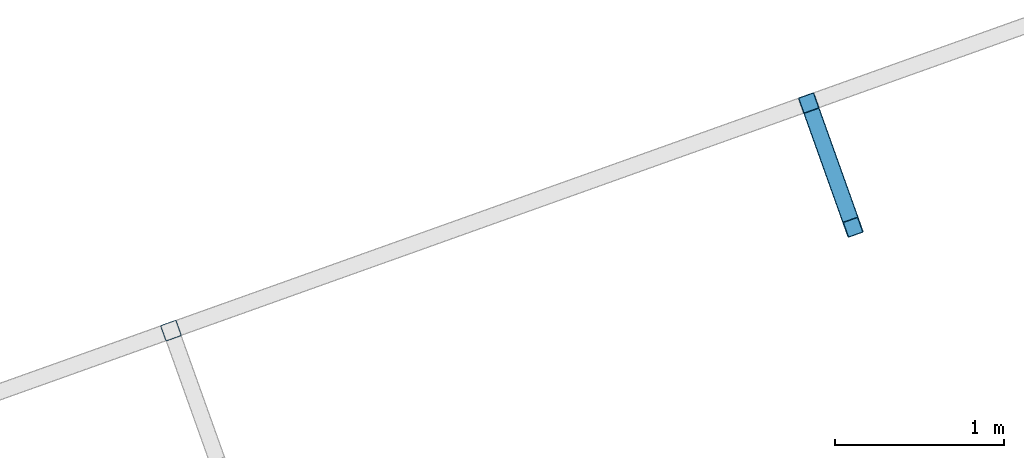
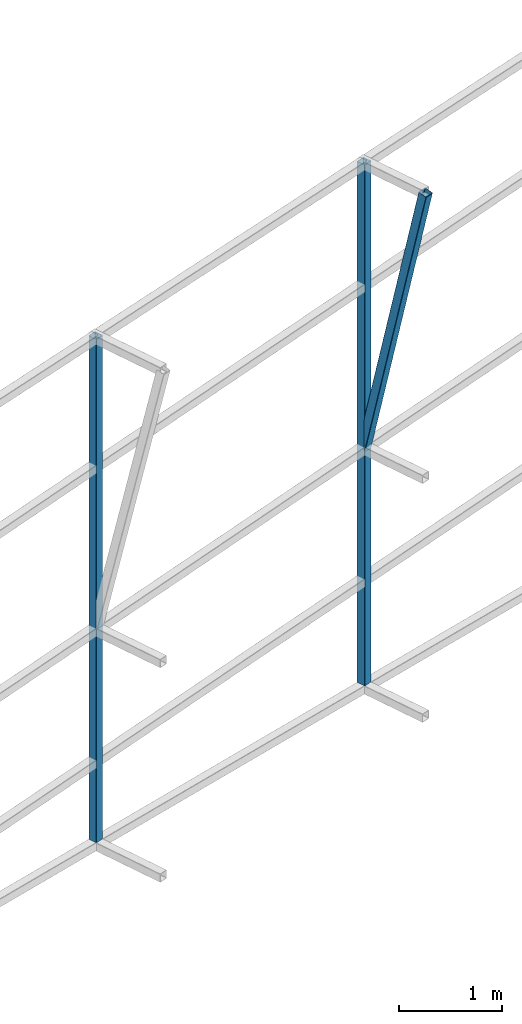
# One storey, part 132 of 215: 2 beams, 1 member, 3 elements without a shape of their own.
"""IFC2X3 building model written with IfcOpenShell, lengths in millimetres."""

from ifc_helpers import new_model, si_unit, frame, origin_with_axes, origin_2d_with_axis, place, context, subcontext, project, spatial, hollow_rectangle, extrude, material, type_object, element, aggregate, save


model = new_model("IFC2X3")

# Units and contexts
model_context = context("Model", 3, precision=1e-05, world=origin_with_axes())
body_context = subcontext(model_context, "Body", "Model", "MODEL_VIEW")
ifc_project = project(units=[si_unit("LENGTHUNIT", "METRE", prefix="MILLI"), si_unit("AREAUNIT", "SQUARE_METRE"), si_unit("VOLUMEUNIT", "CUBIC_METRE"), si_unit("MASSUNIT", "GRAM", prefix="KILO"), si_unit("TIMEUNIT", "SECOND"), si_unit("PLANEANGLEUNIT", "RADIAN"), si_unit("SOLIDANGLEUNIT", "STERADIAN"), si_unit("THERMODYNAMICTEMPERATUREUNIT", "DEGREE_CELSIUS"), si_unit("LUMINOUSINTENSITYUNIT", "LUMEN")], contexts=[model_context])

# Site, building, storey
site_placement = place(None, origin_with_axes())
site = spatial("IfcSite", under=ifc_project, at=site_placement, CompositionType="ELEMENT")
building_placement = place(site_placement, origin_with_axes())
building = spatial("IfcBuilding", under=site, at=building_placement, Name="Undefined", CompositionType="ELEMENT")
storey_placement = place(building_placement, origin_with_axes())
storey = spatial("IfcBuildingStorey", under=building, at=storey_placement, Name="Undefined", CompositionType="ELEMENT", Elevation=0.0)

# Assembly, beam
assembly_1_placement = place(storey_placement, origin_with_axes())
assembly_1 = element("IfcElementAssembly", 1, at=assembly_1_placement, inside=storey, Name="Steel Assembly", AssemblyPlace="NOTDEFINED", PredefinedType="RIGID_FRAME")
ifc_material = material(Name="STEEL/S275JR")
beam_type = type_object("IfcBeamType", PredefinedType="NOTDEFINED")
beam_1_placement = place(assembly_1_placement, frame((116654.915457381, 80219.0317010247, 6722.79260910002), z_axis=(0.941802170974673, 0.33616762299096, 0.0), x_axis=(0.0, 0.0, -1.0)))
beam_1 = element("IfcBeam", 2, at=beam_1_placement, type_object=beam_type, material=ifc_material, Name="LISSE", context=body_context, shape_type="SweptSolid", body=[
    extrude(hollow_rectangle(XDim=100.0, YDim=100.0, WallThickness=4.0, InnerFilletRadius=4.0, OuterFilletRadius=8.0, at=origin_2d_with_axis()), frame((5945.28489561136, -7.27595761418343e-12, 0.0), z_axis=(-1.0, 0.0, 0.0), x_axis=(-6.93889390390723e-18, -1.0, -3.46944695195361e-18)), (0.0, 0.0, 1.0), 5945.3),
])
aggregate(assembly_1, [beam_1])

assembly_2_placement = place(storey_placement, origin_with_axes())
assembly_2 = element("IfcElementAssembly", 3, at=assembly_2_placement, inside=storey, Name="Steel Assembly", AssemblyPlace="NOTDEFINED", PredefinedType="RIGID_FRAME")
beam_2_placement = place(assembly_2_placement, frame((120431.199172063, 81566.9178034923, 6641.91538185944), z_axis=(0.941802170974673, 0.33616762299096, 0.0), x_axis=(0.0, 0.0, -1.0)))
beam_2 = element("IfcBeam", 4, at=beam_2_placement, type_object=beam_type, material=ifc_material, Name="LISSE", context=body_context, shape_type="SweptSolid", body=[
    extrude(hollow_rectangle(XDim=100.0, YDim=100.0, WallThickness=4.0, InnerFilletRadius=4.0, OuterFilletRadius=8.0, at=origin_2d_with_axis()), frame((6151.04561307282, 1.2720064195158e-21, 3.18001604878949e-22), z_axis=(-1.0, 0.0, 0.0), x_axis=(-6.93889390390723e-18, -1.0, -3.46944695195361e-18)), (0.0, 0.0, 1.0), 6151.0),
])
aggregate(assembly_2, [beam_2])

# Assembly, member
assembly_3_placement = place(storey_placement, origin_with_axes())
assembly_3 = element("IfcElementAssembly", 5, at=assembly_3_placement, inside=storey, Name="Steel Assembly", AssemblyPlace="NOTDEFINED", PredefinedType="RIGID_FRAME")
member_type = type_object("IfcMemberType", PredefinedType="NOTDEFINED")
member_placement = place(assembly_3_placement, frame((120693.942104508, 80830.8211517034, 6625.83259409519), z_axis=(0.941802170974673, 0.33616762299096, 0.0), x_axis=(-0.0760385909948084, 0.213028571985461, -0.974082624933511)))
member = element("IfcMember", 6, at=member_placement, type_object=member_type, material=ifc_material, Name="LISSE", context=body_context, shape_type="SweptSolid", body=[
    extrude(hollow_rectangle(XDim=100.0, YDim=100.0, WallThickness=4.0, InnerFilletRadius=4.0, OuterFilletRadius=8.0, at=origin_2d_with_axis()), frame((3455.38930501145, -7.27595761418343e-12, 9.34143626766197e-15), z_axis=(-1.0, 0.0, 0.0), x_axis=(-6.93889390390723e-18, -1.0, -3.46944695195361e-18)), (0.0, 0.0, 1.0), 3455.4),
])
aggregate(assembly_3, [member])

save(model, "model.ifc")
